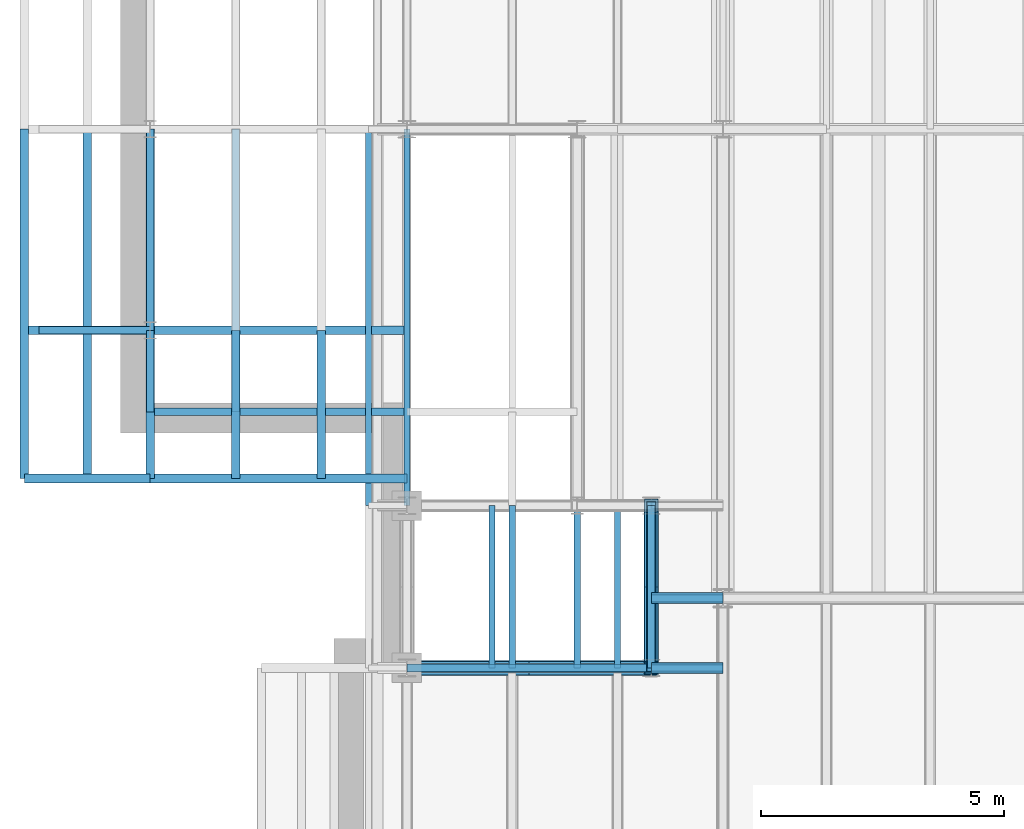
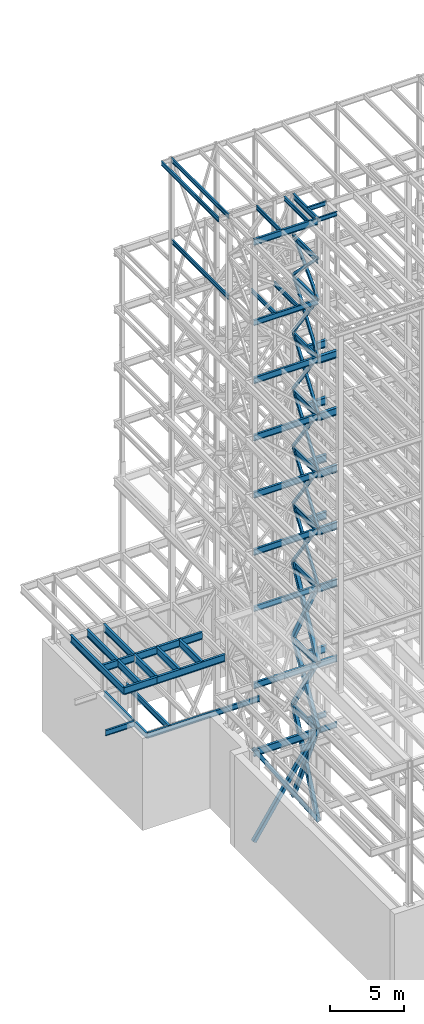
# One storey, part 125 of 150: 76 beams.
"""IFC2X3 building model written with IfcOpenShell, lengths in millimetres."""

from ifc_helpers import new_model, si_unit, frame, origin_with_axes, origin_2d_with_axis, place, context, subcontext, project, spatial, hollow_rectangle, i_section, extrude, material, type_object, element, save


model = new_model("IFC2X3")

# Units and contexts
model_context = context("Model", 3, precision=1e-05, world=origin_with_axes())
body_context = subcontext(model_context, "Body", "Model", "MODEL_VIEW")
ifc_project = project(units=[si_unit("LENGTHUNIT", "METRE", prefix="MILLI"), si_unit("AREAUNIT", "SQUARE_METRE"), si_unit("VOLUMEUNIT", "CUBIC_METRE"), si_unit("MASSUNIT", "GRAM", prefix="KILO"), si_unit("TIMEUNIT", "SECOND"), si_unit("PLANEANGLEUNIT", "RADIAN"), si_unit("SOLIDANGLEUNIT", "STERADIAN"), si_unit("THERMODYNAMICTEMPERATUREUNIT", "DEGREE_CELSIUS"), si_unit("LUMINOUSINTENSITYUNIT", "LUMEN")], contexts=[model_context])

# Site, building, storey
site_placement = place(None, origin_with_axes())
site = spatial("IfcSite", under=ifc_project, at=site_placement, CompositionType="ELEMENT")
building_placement = place(site_placement, origin_with_axes())
building = spatial("IfcBuilding", under=site, at=building_placement, Name="Undefined", CompositionType="ELEMENT")
storey_placement = place(building_placement, origin_with_axes())
storey = spatial("IfcBuildingStorey", under=building, at=storey_placement, Name="Undefined", CompositionType="ELEMENT", Elevation=0.0)

# Beams
ifc_material_1 = material()
beam_type_1 = type_object("IfcBeamType", Name="HSS8X8X3/8", PredefinedType="NOTDEFINED")
for number, where, z_axis, x_axis, name in (
    (1, (10312.39949708, 24384.0, 59207.4), (0.0, 0.708447258296166, 0.705763758075353), (0.0, -0.705763758075351, 0.708447258296168), "BEAM"),
    (2, (10312.39949708, 21043.9, 59207.4), (0.0, -0.708447258296166, 0.705763758075353), (0.0, 0.705763758075351, 0.708447258296168), "BEAM"),
):
    element("IfcBeam", number, at=place(storey_placement, frame(where, z_axis=z_axis, x_axis=x_axis)), inside=storey, type_object=beam_type_1, material=ifc_material_1, Name=name, ObjectType="HSS8X8X3/8", context=body_context, shape_type="SweptSolid", body=[
        extrude(hollow_rectangle(XDim=203.2, YDim=203.2, WallThickness=9.525, InnerFilletRadius=9.5249, OuterFilletRadius=19.0499, at=origin_2d_with_axis()), frame((4732.60349596287, 0.0, 0.0), z_axis=(-1.0, 0.0, 0.0), x_axis=(0.0, -1.0, 0.0)), (0.0, 0.0, 1.0), 4732.60349596287),
    ])
beam_1_placement = place(storey_placement, frame((10312.39949708, 24383.9994993247, 54482.9998858065), z_axis=(0.0, 0.816541853949868, 0.577286238141975), x_axis=(0.0, -0.577286238141973, 0.816541853949869)))
element("IfcBeam", 3, at=beam_1_placement, inside=storey, type_object=beam_type_1, material=ifc_material_1, Name="BEAM", ObjectType="HSS8X8X3/8", context=body_context, shape_type="SweptSolid", body=[
    extrude(hollow_rectangle(XDim=203.2, YDim=203.2, WallThickness=9.525, InnerFilletRadius=9.5249, OuterFilletRadius=19.0499, at=origin_2d_with_axis()), frame((5785.86390302957, 0.0, 0.0), z_axis=(-1.0, 0.0, 0.0), x_axis=(0.0, -1.0, 0.0)), (0.0, 0.0, 1.0), 5785.86390302957),
])
beam_2_placement = place(storey_placement, frame((10312.39949708, 21043.9, 54483.0), z_axis=(0.0, -0.816541853949868, 0.577286238141975), x_axis=(0.0, 0.577286238141973, 0.816541853949869)))
element("IfcBeam", 4, at=beam_2_placement, inside=storey, type_object=beam_type_1, material=ifc_material_1, Name="BEAM", ObjectType="HSS8X8X3/8", context=body_context, shape_type="SweptSolid", body=[
    extrude(hollow_rectangle(XDim=203.2, YDim=203.2, WallThickness=9.525, InnerFilletRadius=9.5249, OuterFilletRadius=19.0499, at=origin_2d_with_axis()), frame((5785.86409881878, 0.0, 3.21179976993034e-13), z_axis=(-1.0, 0.0, 0.0), x_axis=(0.0, -1.0, 0.0)), (0.0, 0.0, 1.0), 5785.86409881878),
])
for number, where, z_axis, x_axis, name in (
    (5, (10312.39949708, 24384.0, 40309.8), (0.0, 0.816541853949868, 0.577286238141975), (0.0, -0.577286238141973, 0.816541853949869), "BEAM"),
    (6, (10312.39949708, 21043.9, 40309.8), (0.0, -0.816541853949868, 0.577286238141975), (0.0, 0.577286238141973, 0.816541853949869), "BEAM"),
):
    element("IfcBeam", number, at=place(storey_placement, frame(where, z_axis=z_axis, x_axis=x_axis)), inside=storey, type_object=beam_type_1, material=ifc_material_1, Name=name, ObjectType="HSS8X8X3/8", context=body_context, shape_type="SweptSolid", body=[
        extrude(hollow_rectangle(XDim=203.2, YDim=203.2, WallThickness=9.525, InnerFilletRadius=9.5249, OuterFilletRadius=19.0499, at=origin_2d_with_axis()), frame((5785.86409881878, 0.0, 3.21179976993034e-13), z_axis=(-1.0, 0.0, 0.0), x_axis=(0.0, -1.0, 0.0)), (0.0, 0.0, 1.0), 5785.86409881877),
    ])
for number, where, z_axis, x_axis, name in (
    (7, (10312.39949708, 24384.0, 35585.4), (0.0, 0.816541853949868, 0.577286238141975), (0.0, -0.577286238141973, 0.816541853949869), "BEAM"),
    (8, (10312.39949708, 21043.9, 35585.4), (0.0, -0.816541853949868, 0.577286238141975), (0.0, 0.577286238141973, 0.816541853949869), "BEAM"),
):
    element("IfcBeam", number, at=place(storey_placement, frame(where, z_axis=z_axis, x_axis=x_axis)), inside=storey, type_object=beam_type_1, material=ifc_material_1, Name=name, ObjectType="HSS8X8X3/8", context=body_context, shape_type="SweptSolid", body=[
        extrude(hollow_rectangle(XDim=203.2, YDim=203.2, WallThickness=9.525, InnerFilletRadius=9.5249, OuterFilletRadius=19.0499, at=origin_2d_with_axis()), frame((5785.86409881878, 0.0, 3.21179976993034e-13), z_axis=(-1.0, 0.0, 0.0), x_axis=(0.0, -1.0, 0.0)), (0.0, 0.0, 1.0), 5785.86409881878),
    ])
ifc_material_2 = material(Name="STEEL/A992")
beam_type_2 = type_object("IfcBeamType", Name="W18X35", PredefinedType="NOTDEFINED")
for number, where, z_axis, x_axis, name in (
    (9, (10312.39949708, 21043.8997539549, 62334.7746954019), (0.0, 0.0, 1.0), (0.0, 1.0, 0.0), "BEAM"),
    (10, (10312.39949708, 21043.9, 65687.575), (0.0, 0.0, 1.0), (0.0, 1.0, 0.0), "BEAM"),
    (11, (10312.39949708, 21043.9, 58981.975), (0.0, 0.0, 1.0), (0.0, 1.0, 0.0), "BEAM"),
):
    element("IfcBeam", number, at=place(storey_placement, frame(where, z_axis=z_axis, x_axis=x_axis)), inside=storey, type_object=beam_type_2, material=ifc_material_2, Name=name, ObjectType="W18X35", context=body_context, shape_type="SweptSolid", body=[
        extrude(i_section(OverallWidth=152.4, OverallDepth=450.85, WebThickness=7.9375, FlangeThickness=10.795, FilletRadius=17.78, at=origin_2d_with_axis()), frame((3340.1, 0.0, 0.0), z_axis=(-1.0, 0.0, 0.0), x_axis=(0.0, -1.0, 0.0)), (0.0, 0.0, 1.0), 3340.1),
    ])
beam_3_placement = place(storey_placement, frame((5283.2, 21043.9, 58981.975), z_axis=(0.0, 0.0, 1.0), x_axis=(1.0, 0.0, 0.0)))
element("IfcBeam", 12, at=beam_3_placement, inside=storey, type_object=beam_type_2, material=ifc_material_2, Name="BEAM", ObjectType="W18X35", context=body_context, shape_type="SweptSolid", body=[
    extrude(i_section(OverallWidth=152.4, OverallDepth=450.85, WebThickness=7.9375, FlangeThickness=10.795, FilletRadius=17.78, at=origin_2d_with_axis()), frame((5029.19949708, 0.0, 0.0), z_axis=(-1.0, 0.0, 0.0), x_axis=(0.0, -1.0, 0.0)), (0.0, 0.0, 1.0), 5029.19949708),
])
for number, where, z_axis, x_axis, name in (
    (13, (10312.39949708, 21043.9, 54257.575), (0.0, 0.0, 1.0), (0.0, 1.0, 0.0), "BEAM"),
    (14, (10312.39949708, 21043.9, 49533.175), (0.0, 0.0, 1.0), (0.0, 1.0, 0.0), "BEAM"),
    (15, (10312.39949708, 21043.9, 44808.775), (0.0, 0.0, 1.0), (0.0, 1.0, 0.0), "BEAM"),
    (16, (10312.39949708, 21043.9, 40084.375), (0.0, 0.0, 1.0), (0.0, 1.0, 0.0), "BEAM"),
    (17, (10312.39949708, 21043.9, 35359.975), (0.0, 0.0, 1.0), (0.0, 1.0, 0.0), "BEAM"),
):
    element("IfcBeam", number, at=place(storey_placement, frame(where, z_axis=z_axis, x_axis=x_axis)), inside=storey, type_object=beam_type_2, material=ifc_material_2, Name=name, ObjectType="W18X35", context=body_context, shape_type="SweptSolid", body=[
        extrude(i_section(OverallWidth=152.4, OverallDepth=450.85, WebThickness=7.9375, FlangeThickness=10.795, FilletRadius=17.78, at=origin_2d_with_axis()), frame((3340.1, 0.0, 0.0), z_axis=(-1.0, 0.0, 0.0), x_axis=(0.0, -1.0, 0.0)), (0.0, 0.0, 1.0), 3340.1),
    ])
beam_4_placement = place(storey_placement, frame((5283.2, 21043.9, 35359.975), z_axis=(0.0, 0.0, 1.0), x_axis=(1.0, 0.0, 0.0)))
element("IfcBeam", 18, at=beam_4_placement, inside=storey, type_object=beam_type_2, material=ifc_material_2, Name="BEAM", ObjectType="W18X35", context=body_context, shape_type="SweptSolid", body=[
    extrude(i_section(OverallWidth=152.4, OverallDepth=450.85, WebThickness=7.9375, FlangeThickness=10.795, FilletRadius=17.78, at=origin_2d_with_axis()), frame((5029.19949708, 0.0, 0.0), z_axis=(-1.0, 0.0, 0.0), x_axis=(0.0, -1.0, 0.0)), (0.0, 0.0, 1.0), 5029.19949708),
])
beam_5_placement = place(storey_placement, frame((10312.39949708, 21043.9, 29060.775), z_axis=(0.0, 0.0, 1.0), x_axis=(0.0, 1.0, 0.0)))
element("IfcBeam", 19, at=beam_5_placement, inside=storey, type_object=beam_type_2, material=ifc_material_2, Name="BEAM", ObjectType="W18X35", context=body_context, shape_type="SweptSolid", body=[
    extrude(i_section(OverallWidth=152.4, OverallDepth=450.85, WebThickness=7.9375, FlangeThickness=10.795, FilletRadius=17.78, at=origin_2d_with_axis()), frame((3340.1, 0.0, 0.0), z_axis=(-1.0, 0.0, 0.0), x_axis=(0.0, -1.0, 0.0)), (0.0, 0.0, 1.0), 3340.1),
])
beam_6_placement = place(storey_placement, frame((1761.06666666667, 26314.4, 23548.975), z_axis=(0.0, 0.0, 1.0), x_axis=(0.0, 1.0, 0.0)))
element("IfcBeam", 20, at=beam_6_placement, inside=storey, type_object=beam_type_2, material=ifc_material_2, Name="BEAM", ObjectType="W18X35", context=body_context, shape_type="SweptSolid", body=[
    extrude(i_section(OverallWidth=152.4, OverallDepth=450.85, WebThickness=7.9375, FlangeThickness=10.795, FilletRadius=17.78, at=origin_2d_with_axis()), frame((5816.59941834001, 0.0, 0.0), z_axis=(-1.0, 0.0, 0.0), x_axis=(0.0, -1.0, 0.0)), (0.0, 0.0, 1.0), 5816.59941834001),
])
beam_7_placement = place(storey_placement, frame((0.0, 27990.8, 23548.975), z_axis=(0.0, 0.0, 1.0), x_axis=(0.0, 1.0, 0.0)))
element("IfcBeam", 21, at=beam_7_placement, inside=storey, type_object=beam_type_2, material=ifc_material_2, Name="BEAM", ObjectType="W18X35", context=body_context, shape_type="SweptSolid", body=[
    extrude(i_section(OverallWidth=152.4, OverallDepth=450.85, WebThickness=7.9375, FlangeThickness=10.795, FilletRadius=17.78, at=origin_2d_with_axis()), frame((4140.2, 0.0, 0.0), z_axis=(-1.0, 0.0, 0.0), x_axis=(0.0, -1.0, 0.0)), (0.0, 0.0, 1.0), 4140.2),
])
beam_8_placement = place(storey_placement, frame((-2286.0, 27990.8, 23548.975), z_axis=(0.0, 0.0, 1.0), x_axis=(1.0, 0.0, 0.0)))
element("IfcBeam", 22, at=beam_8_placement, inside=storey, type_object=beam_type_2, material=ifc_material_2, Name="BEAM", ObjectType="W18X35", context=body_context, shape_type="SweptSolid", body=[
    extrude(i_section(OverallWidth=152.4, OverallDepth=450.85, WebThickness=7.9375, FlangeThickness=10.795, FilletRadius=17.78, at=origin_2d_with_axis()), frame((2286.0, 0.0, 0.0), z_axis=(-1.0, 0.0, 0.0), x_axis=(0.0, -1.0, 0.0)), (0.0, 0.0, 1.0), 2286.0),
])
beam_9_placement = place(storey_placement, frame((0.0, 26314.4, 23548.975), z_axis=(0.0, 0.0, 1.0), x_axis=(0.0, 1.0, 0.0)))
element("IfcBeam", 23, at=beam_9_placement, inside=storey, type_object=beam_type_2, material=ifc_material_2, Name="BEAM", ObjectType="W18X35", context=body_context, shape_type="SweptSolid", body=[
    extrude(i_section(OverallWidth=152.4, OverallDepth=450.85, WebThickness=7.9375, FlangeThickness=10.795, FilletRadius=17.78, at=origin_2d_with_axis()), frame((1676.4, 0.0, 0.0), z_axis=(-1.0, 0.0, 0.0), x_axis=(0.0, -1.0, 0.0)), (0.0, 0.0, 1.0), 1676.4),
])
beam_10_placement = place(storey_placement, frame((0.0, 26314.4, 23548.975), z_axis=(0.0, 0.0, 1.0), x_axis=(1.0, 0.0, 0.0)))
element("IfcBeam", 24, at=beam_10_placement, inside=storey, type_object=beam_type_2, material=ifc_material_2, Name="BEAM", ObjectType="W18X35", context=body_context, shape_type="SweptSolid", body=[
    extrude(i_section(OverallWidth=152.4, OverallDepth=450.85, WebThickness=7.9375, FlangeThickness=10.795, FilletRadius=17.78, at=origin_2d_with_axis()), frame((8788.39949708, 0.0, 0.0), z_axis=(-1.0, 0.0, 0.0), x_axis=(0.0, -1.0, 0.0)), (0.0, 0.0, 1.0), 8788.39949708),
])
for number, where, z_axis, x_axis, name in (
    (25, (10312.39949708, 22479.0, 23548.975), (0.0, 0.0, 1.0), (1.0, 0.0, 0.0), "BEAM"),
    (26, (10312.39949708, 21043.9, 23548.975), (0.0, 0.0, 1.0), (1.0, 0.0, 0.0), "BEAM"),
):
    element("IfcBeam", number, at=place(storey_placement, frame(where, z_axis=z_axis, x_axis=x_axis)), inside=storey, type_object=beam_type_2, material=ifc_material_2, Name=name, ObjectType="W18X35", context=body_context, shape_type="SweptSolid", body=[
        extrude(i_section(OverallWidth=152.4, OverallDepth=450.85, WebThickness=7.9375, FlangeThickness=10.795, FilletRadius=17.78, at=origin_2d_with_axis()), frame((1473.20050292, 0.0, 0.0), z_axis=(-1.0, 0.0, 0.0), x_axis=(0.0, -1.0, 0.0)), (0.0, 0.0, 1.0), 1473.20050292),
    ])
beam_11_placement = place(storey_placement, frame((10312.39949708, 21043.9, 23548.975), z_axis=(0.0, 0.0, 1.0), x_axis=(0.0, 1.0, 0.0)))
element("IfcBeam", 27, at=beam_11_placement, inside=storey, type_object=beam_type_2, material=ifc_material_2, Name="BEAM", ObjectType="W18X35", context=body_context, shape_type="SweptSolid", body=[
    extrude(i_section(OverallWidth=152.4, OverallDepth=450.85, WebThickness=7.9375, FlangeThickness=10.795, FilletRadius=17.78, at=origin_2d_with_axis()), frame((3340.1, 0.0, 0.0), z_axis=(-1.0, 0.0, 0.0), x_axis=(0.0, -1.0, 0.0)), (0.0, 0.0, 1.0), 3340.09999999999),
])
beam_type_3 = type_object("IfcBeamType", Name="HSS8X8X1/4", PredefinedType="NOTDEFINED")
for number, where, z_axis, x_axis, name in (
    (28, (10312.39949708, 24384.0, 49758.6), (0.0, 0.816541853949868, 0.577286238141975), (0.0, -0.577286238141973, 0.816541853949869), "BEAM"),
    (29, (10312.39949708, 21043.9, 49758.6), (0.0, -0.816541853949868, 0.577286238141975), (0.0, 0.577286238141973, 0.816541853949869), "BEAM"),
):
    element("IfcBeam", number, at=place(storey_placement, frame(where, z_axis=z_axis, x_axis=x_axis)), inside=storey, type_object=beam_type_3, material=ifc_material_1, Name=name, ObjectType="HSS8X8X1/4", context=body_context, shape_type="SweptSolid", body=[
        extrude(hollow_rectangle(XDim=203.2, YDim=203.2, WallThickness=6.35, InnerFilletRadius=6.3499, OuterFilletRadius=12.6999, at=origin_2d_with_axis()), frame((5785.86409881878, 0.0, 3.21179976993034e-13), z_axis=(-1.0, 0.0, 0.0), x_axis=(0.0, -1.0, 0.0)), (0.0, 0.0, 1.0), 5785.86409881878),
    ])
beam_12_placement = place(storey_placement, frame((10312.39949708, 24384.0, 45034.2), z_axis=(0.0, 0.816541853949868, 0.577286238141975), x_axis=(0.0, -0.577286238141973, 0.816541853949869)))
element("IfcBeam", 30, at=beam_12_placement, inside=storey, type_object=beam_type_3, material=ifc_material_1, Name="BEAM", ObjectType="HSS8X8X1/4", context=body_context, shape_type="SweptSolid", body=[
    extrude(hollow_rectangle(XDim=203.2, YDim=203.2, WallThickness=6.35, InnerFilletRadius=6.3499, OuterFilletRadius=12.6999, at=origin_2d_with_axis()), frame((5785.86440767293, 0.0, 0.0), z_axis=(-1.0, 0.0, 0.0), x_axis=(0.0, -1.0, 0.0)), (0.0, 0.0, 1.0), 5785.86440767293),
])
beam_13_placement = place(storey_placement, frame((10312.39949708, 21043.9, 45034.2), z_axis=(0.0, -0.816541853949868, 0.577286238141975), x_axis=(0.0, 0.577286238141973, 0.816541853949869)))
element("IfcBeam", 31, at=beam_13_placement, inside=storey, type_object=beam_type_3, material=ifc_material_1, Name="BEAM", ObjectType="HSS8X8X1/4", context=body_context, shape_type="SweptSolid", body=[
    extrude(hollow_rectangle(XDim=203.2, YDim=203.2, WallThickness=6.35, InnerFilletRadius=6.3499, OuterFilletRadius=12.6999, at=origin_2d_with_axis()), frame((5785.86409881878, 0.0, 3.21179976993034e-13), z_axis=(-1.0, 0.0, 0.0), x_axis=(0.0, -1.0, 0.0)), (0.0, 0.0, 1.0), 5785.86409881877),
])
beam_type_4 = type_object("IfcBeamType", Name="HSS12X12X5/8", PredefinedType="NOTDEFINED")
beam_14_placement = place(storey_placement, frame((10312.39949708, 21043.9001130334, 16154.4), z_axis=(0.834609454374485, 0.0, 0.550842135887156), x_axis=(-0.550842135887154, 0.0, 0.834609454374486)))
element("IfcBeam", 32, at=beam_14_placement, inside=storey, type_object=beam_type_4, material=ifc_material_1, Name="BEAM", ObjectType="HSS12X12X5/8", context=body_context, shape_type="SweptSolid", body=[
    extrude(hollow_rectangle(XDim=304.8, YDim=304.8, WallThickness=15.875, InnerFilletRadius=15.875, OuterFilletRadius=31.75, at=origin_2d_with_axis()), frame((9130.01903510775, 0.0, 0.0), z_axis=(-1.0, 0.0, 0.0), x_axis=(0.0, -1.0, 0.0)), (0.0, 0.0, 1.0), 9130.01903510775),
])
beam_15_placement = place(storey_placement, frame((5283.2, 21043.9, 16154.4), z_axis=(-0.834609454374487, 0.0, 0.550842135887154), x_axis=(0.550842135887154, 0.0, 0.834609454374486)))
element("IfcBeam", 33, at=beam_15_placement, inside=storey, type_object=beam_type_4, material=ifc_material_1, Name="BEAM", ObjectType="HSS12X12X5/8", context=body_context, shape_type="SweptSolid", body=[
    extrude(hollow_rectangle(XDim=304.8, YDim=304.8, WallThickness=15.875, InnerFilletRadius=15.875, OuterFilletRadius=31.75, at=origin_2d_with_axis()), frame((9130.01903510775, 0.0, 0.0), z_axis=(-1.0, 0.0, 0.0), x_axis=(0.0, -1.0, 0.0)), (0.0, 0.0, 1.0), 9130.01903510774),
])
for number, where, z_axis, x_axis, name in (
    (34, (10312.39949708, 24384.0, 29286.2), (0.0, 0.883484433084898, 0.468460517543001), (0.0, -0.468460517543001, 0.883484433084898), "BEAM"),
    (35, (10312.39949708, 21043.9, 29286.2), (0.0, -0.883484433084898, 0.468460517543001), (0.0, 0.468460517543001, 0.883484433084898), "BEAM"),
):
    element("IfcBeam", number, at=place(storey_placement, frame(where, z_axis=z_axis, x_axis=x_axis)), inside=storey, type_object=beam_type_4, material=ifc_material_1, Name=name, ObjectType="HSS12X12X5/8", context=body_context, shape_type="SweptSolid", body=[
        extrude(hollow_rectangle(XDim=304.8, YDim=304.8, WallThickness=15.875, InnerFilletRadius=15.875, OuterFilletRadius=31.75, at=origin_2d_with_axis()), frame((7129.95011553376, 0.0, 0.0), z_axis=(-1.0, 0.0, 0.0), x_axis=(0.0, -1.0, 0.0)), (0.0, 0.0, 1.0), 7129.95011553376),
    ])
for number, where, z_axis, x_axis, name in (
    (36, (10312.39949708, 24384.0, 23774.4), (0.0, 0.855224291154239, 0.518258055238632), (0.0, -0.518258055238631, 0.85522429115424), "BEAM"),
    (37, (10312.39949708, 21043.9, 23774.4), (0.0, -0.855224291154239, 0.518258055238632), (0.0, 0.518258055238631, 0.85522429115424), "BEAM"),
):
    element("IfcBeam", number, at=place(storey_placement, frame(where, z_axis=z_axis, x_axis=x_axis)), inside=storey, type_object=beam_type_4, material=ifc_material_1, Name=name, ObjectType="HSS12X12X5/8", context=body_context, shape_type="SweptSolid", body=[
        extrude(hollow_rectangle(XDim=304.8, YDim=304.8, WallThickness=15.875, InnerFilletRadius=15.875, OuterFilletRadius=31.75, at=origin_2d_with_axis()), frame((6444.8589782865, 0.0, -7.15523082815583e-13), z_axis=(-1.0, 0.0, 0.0), x_axis=(0.0, -1.0, 0.0)), (0.0, 0.0, 1.0), 6444.85897828649),
    ])
for number, where, z_axis, x_axis, name in (
    (38, (10312.39949708, 24384.0, 16154.4), (0.0, 0.91587685388345, 0.401459323618912), (0.0, -0.401459323618911, 0.91587685388345), "BEAM"),
    (39, (10312.39949708, 21043.9, 16154.4), (0.0, -0.91587685388345, 0.401459323618912), (0.0, 0.401459323618911, 0.91587685388345), "BEAM"),
):
    element("IfcBeam", number, at=place(storey_placement, frame(where, z_axis=z_axis, x_axis=x_axis)), inside=storey, type_object=beam_type_4, material=ifc_material_1, Name=name, ObjectType="HSS12X12X5/8", context=body_context, shape_type="SweptSolid", body=[
        extrude(hollow_rectangle(XDim=304.8, YDim=304.8, WallThickness=15.875, InnerFilletRadius=15.875, OuterFilletRadius=31.75, at=origin_2d_with_axis()), frame((8319.89591341142, 0.0, 4.61847000277705e-13), z_axis=(-1.0, 0.0, 0.0), x_axis=(0.0, -1.0, 0.0)), (0.0, 0.0, 1.0), 8319.89591341142),
    ])
beam_type_5 = type_object("IfcBeamType", Name="W21X50", PredefinedType="NOTDEFINED")
beam_16_placement = place(storey_placement, frame((5283.2, 21043.9, 65647.8875), z_axis=(0.0, 0.0, 1.0), x_axis=(1.0, 0.0, 0.0)))
element("IfcBeam", 40, at=beam_16_placement, inside=storey, type_object=beam_type_5, material=ifc_material_2, Name="BEAM", ObjectType="W21X50", context=body_context, shape_type="SweptSolid", body=[
    extrude(i_section(OverallWidth=165.862, OverallDepth=530.225, WebThickness=9.5249, FlangeThickness=13.589, FilletRadius=18.1609, at=origin_2d_with_axis()), frame((5029.19949708, 0.0, 0.0), z_axis=(-1.0, 0.0, 0.0), x_axis=(0.0, -1.0, 0.0)), (0.0, 0.0, 1.0), 5029.19949708),
])
beam_type_6 = type_object("IfcBeamType", Name="W24X68", PredefinedType="NOTDEFINED")
for number, where, z_axis, x_axis, name in (
    (41, (10312.39949708, 21043.9, 54181.375), (0.0, 0.0, 1.0), (1.0, 0.0, 0.0), "BEAM"),
    (42, (10312.39949708, 22479.0, 54181.375), (0.0, 0.0, 1.0), (1.0, 0.0, 0.0), "BEAM"),
    (43, (10312.39949708, 21043.9, 49456.975), (0.0, 0.0, 1.0), (1.0, 0.0, 0.0), "BEAM"),
    (44, (10312.39949708, 22479.0, 49456.975), (0.0, 0.0, 1.0), (1.0, 0.0, 0.0), "BEAM"),
    (45, (10312.39949708, 21043.9, 44732.575), (0.0, 0.0, 1.0), (1.0, 0.0, 0.0), "BEAM"),
    (46, (10312.39949708, 22479.0, 44732.575), (0.0, 0.0, 1.0), (1.0, 0.0, 0.0), "BEAM"),
    (47, (10312.39949708, 21043.9, 40008.175), (0.0, 0.0, 1.0), (1.0, 0.0, 0.0), "BEAM"),
    (48, (10312.39949708, 22479.0, 40008.175), (0.0, 0.0, 1.0), (1.0, 0.0, 0.0), "BEAM"),
):
    element("IfcBeam", number, at=place(storey_placement, frame(where, z_axis=z_axis, x_axis=x_axis)), inside=storey, type_object=beam_type_6, material=ifc_material_2, Name=name, ObjectType="W24X68", context=body_context, shape_type="SweptSolid", body=[
        extrude(i_section(OverallWidth=227.838, OverallDepth=603.25, WebThickness=11.1125, FlangeThickness=14.859, FilletRadius=23.2409, at=origin_2d_with_axis()), frame((1473.20050292, 0.0, 0.0), z_axis=(-1.0, 0.0, 0.0), x_axis=(0.0, -1.0, 0.0)), (0.0, 0.0, 1.0), 1473.20050292),
    ])
beam_type_7 = type_object("IfcBeamType", Name="W14X22", PredefinedType="NOTDEFINED")
beam_17_placement = place(storey_placement, frame((4495.8, 24384.0, 65738.375), z_axis=(0.0, 0.0, 1.0), x_axis=(0.0, 1.0, 0.0)))
element("IfcBeam", 49, at=beam_17_placement, inside=storey, type_object=beam_type_7, material=ifc_material_2, Name="BEAM", ObjectType="W14X22", context=body_context, shape_type="SweptSolid", body=[
    extrude(i_section(OverallWidth=127.0, OverallDepth=349.25, WebThickness=6.3499, FlangeThickness=8.509, FilletRadius=18.4785, at=origin_2d_with_axis()), frame((7746.99845060008, 0.0, 0.0), z_axis=(-1.0, 0.0, 0.0), x_axis=(0.0, -1.0, 0.0)), (0.0, 0.0, 1.0), 7746.99845060008),
])
for number, where, z_axis, x_axis, name in (
    (50, (10312.39949708, 22479.0, 65738.375), (0.0, 0.0, 1.0), (1.0, 0.0, 0.0), "BEAM"),
    (51, (10312.39949708, 21043.9, 65738.375), (0.0, 0.0, 1.0), (1.0, 0.0, 0.0), "BEAM"),
):
    element("IfcBeam", number, at=place(storey_placement, frame(where, z_axis=z_axis, x_axis=x_axis)), inside=storey, type_object=beam_type_7, material=ifc_material_2, Name=name, ObjectType="W14X22", context=body_context, shape_type="SweptSolid", body=[
        extrude(i_section(OverallWidth=127.0, OverallDepth=349.25, WebThickness=6.3499, FlangeThickness=8.509, FilletRadius=18.4785, at=origin_2d_with_axis()), frame((1473.20050292, 0.0, 0.0), z_axis=(-1.0, 0.0, 0.0), x_axis=(0.0, -1.0, 0.0)), (0.0, 0.0, 1.0), 1473.20050292),
    ])
for number, where, z_axis, x_axis, name in (
    (52, (7450.66666666667, 21043.9, 65738.375), (0.0, 0.0, 1.0), (0.0, 1.0, 0.0), "BEAM"),
    (53, (9618.13333333333, 21043.9, 65738.375), (0.0, 0.0, 1.0), (0.0, 1.0, 0.0), "BEAM"),
):
    element("IfcBeam", number, at=place(storey_placement, frame(where, z_axis=z_axis, x_axis=x_axis)), inside=storey, type_object=beam_type_7, material=ifc_material_2, Name=name, ObjectType="W14X22", context=body_context, shape_type="SweptSolid", body=[
        extrude(i_section(OverallWidth=127.0, OverallDepth=349.25, WebThickness=6.3499, FlangeThickness=8.509, FilletRadius=18.4785, at=origin_2d_with_axis()), frame((3340.1, 0.0, 0.0), z_axis=(-1.0, 0.0, 0.0), x_axis=(0.0, -1.0, 0.0)), (0.0, 0.0, 1.0), 3340.1),
    ])
beam_18_placement = place(storey_placement, frame((5283.2, 24384.0, 65738.375), z_axis=(0.0, 0.0, 1.0), x_axis=(0.0, 1.0, 0.0)))
element("IfcBeam", 54, at=beam_18_placement, inside=storey, type_object=beam_type_7, material=ifc_material_2, Name="BEAM", ObjectType="W14X22", context=body_context, shape_type="SweptSolid", body=[
    extrude(i_section(OverallWidth=127.0, OverallDepth=349.25, WebThickness=6.3499, FlangeThickness=8.509, FilletRadius=18.4785, at=origin_2d_with_axis()), frame((7746.9992253, 0.0, 0.0), z_axis=(-1.0, 0.0, 0.0), x_axis=(0.0, -1.0, 0.0)), (0.0, 0.0, 1.0), 7746.9992253),
])
for number, where, z_axis, x_axis, name in (
    (55, (7035.79974854, 21043.9, 59032.775), (0.0, 0.0, 1.0), (0.0, 1.0, 0.0), "BEAM"),
    (56, (8788.39949708, 21043.9, 59032.775), (0.0, 0.0, 1.0), (0.0, 1.0, 0.0), "BEAM"),
):
    element("IfcBeam", number, at=place(storey_placement, frame(where, z_axis=z_axis, x_axis=x_axis)), inside=storey, type_object=beam_type_7, material=ifc_material_2, Name=name, ObjectType="W14X22", context=body_context, shape_type="SweptSolid", body=[
        extrude(i_section(OverallWidth=127.0, OverallDepth=349.25, WebThickness=6.3499, FlangeThickness=8.509, FilletRadius=18.4785, at=origin_2d_with_axis()), frame((3340.1, 0.0, 0.0), z_axis=(-1.0, 0.0, 0.0), x_axis=(0.0, -1.0, 0.0)), (0.0, 0.0, 1.0), 3340.1),
    ])
beam_19_placement = place(storey_placement, frame((5283.2, 24384.0, 59032.775), z_axis=(0.0, 0.0, 1.0), x_axis=(0.0, 1.0, 0.0)))
element("IfcBeam", 57, at=beam_19_placement, inside=storey, type_object=beam_type_7, material=ifc_material_2, Name="BEAM", ObjectType="W14X22", context=body_context, shape_type="SweptSolid", body=[
    extrude(i_section(OverallWidth=127.0, OverallDepth=349.25, WebThickness=6.3499, FlangeThickness=8.509, FilletRadius=18.4785, at=origin_2d_with_axis()), frame((7747.0, 0.0, 0.0), z_axis=(-1.0, 0.0, 0.0), x_axis=(0.0, -1.0, 0.0)), (0.0, 0.0, 1.0), 7747.0),
])
beam_type_8 = type_object("IfcBeamType", Name="W24X55", PredefinedType="NOTDEFINED")
for number, where, z_axis, x_axis, name in (
    (58, (3522.13333333333, 24942.8, 28986.1625), (0.0, 0.0, 1.0), (0.0, 1.0, 0.0), "BEAM"),
    (59, (1761.06666666667, 24942.8, 28986.1625), (0.0, 0.0, 1.0), (0.0, 1.0, 0.0), "BEAM"),
):
    element("IfcBeam", number, at=place(storey_placement, frame(where, z_axis=z_axis, x_axis=x_axis)), inside=storey, type_object=beam_type_8, material=ifc_material_2, Name=name, ObjectType="W24X55", context=body_context, shape_type="SweptSolid", body=[
        extrude(i_section(OverallWidth=178.054, OverallDepth=600.075, WebThickness=9.5249, FlangeThickness=12.827, FilletRadius=23.6854, at=origin_2d_with_axis()), frame((3048.0, 0.0, 0.0), z_axis=(-1.0, 0.0, 0.0), x_axis=(0.0, -1.0, 0.0)), (0.0, 0.0, 1.0), 3048.0),
    ])
beam_20_placement = place(storey_placement, frame((0.0, 24942.8, 28986.1625), z_axis=(0.0, 0.0, 1.0), x_axis=(1.0, 0.0, 0.0)))
element("IfcBeam", 60, at=beam_20_placement, inside=storey, type_object=beam_type_8, material=ifc_material_2, Name="BEAM", ObjectType="W24X55", context=body_context, shape_type="SweptSolid", body=[
    extrude(i_section(OverallWidth=178.054, OverallDepth=600.075, WebThickness=9.5249, FlangeThickness=12.827, FilletRadius=23.6854, at=origin_2d_with_axis()), frame((5283.2, 0.0, 0.0), z_axis=(-1.0, 0.0, 0.0), x_axis=(0.0, -1.0, 0.0)), (0.0, 0.0, 1.0), 5283.2),
])
beam_21_placement = place(storey_placement, frame((-1295.4, 27990.8, 28986.1625), z_axis=(0.0, 0.0, 1.0), x_axis=(0.0, 1.0, 0.0)))
element("IfcBeam", 61, at=beam_21_placement, inside=storey, type_object=beam_type_8, material=ifc_material_2, Name="BEAM", ObjectType="W24X55", context=body_context, shape_type="SweptSolid", body=[
    extrude(i_section(OverallWidth=178.054, OverallDepth=600.075, WebThickness=9.5249, FlangeThickness=12.827, FilletRadius=23.6854, at=origin_2d_with_axis()), frame((4140.2, 0.0, 0.0), z_axis=(-1.0, 0.0, 0.0), x_axis=(0.0, -1.0, 0.0)), (0.0, 0.0, 1.0), 4140.2),
])
beam_22_placement = place(storey_placement, frame((-1295.4, 24942.8, 28986.1625), z_axis=(0.0, 0.0, 1.0), x_axis=(0.0, 1.0, 0.0)))
element("IfcBeam", 62, at=beam_22_placement, inside=storey, type_object=beam_type_8, material=ifc_material_2, Name="BEAM", ObjectType="W24X55", context=body_context, shape_type="SweptSolid", body=[
    extrude(i_section(OverallWidth=178.054, OverallDepth=600.075, WebThickness=9.5249, FlangeThickness=12.827, FilletRadius=23.6854, at=origin_2d_with_axis()), frame((3048.0, 0.0, 0.0), z_axis=(-1.0, 0.0, 0.0), x_axis=(0.0, -1.0, 0.0)), (0.0, 0.0, 1.0), 3048.0),
])
beam_23_placement = place(storey_placement, frame((-2590.8, 24942.8, 28986.1625), z_axis=(0.0, 0.0, 1.0), x_axis=(1.0, 0.0, 0.0)))
element("IfcBeam", 63, at=beam_23_placement, inside=storey, type_object=beam_type_8, material=ifc_material_2, Name="BEAM", ObjectType="W24X55", context=body_context, shape_type="SweptSolid", body=[
    extrude(i_section(OverallWidth=178.054, OverallDepth=600.075, WebThickness=9.5249, FlangeThickness=12.827, FilletRadius=23.6854, at=origin_2d_with_axis()), frame((2590.8, 0.0, 0.0), z_axis=(-1.0, 0.0, 0.0), x_axis=(0.0, -1.0, 0.0)), (0.0, 0.0, 1.0), 2590.8),
])
beam_24_placement = place(storey_placement, frame((0.0, 27990.8, 28986.1625), z_axis=(0.0, 0.0, 1.0), x_axis=(0.0, 1.0, 0.0)))
element("IfcBeam", 64, at=beam_24_placement, inside=storey, type_object=beam_type_8, material=ifc_material_2, Name="BEAM", ObjectType="W24X55", context=body_context, shape_type="SweptSolid", body=[
    extrude(i_section(OverallWidth=178.054, OverallDepth=600.075, WebThickness=9.5249, FlangeThickness=12.827, FilletRadius=23.6854, at=origin_2d_with_axis()), frame((4140.2, 0.0, 0.0), z_axis=(-1.0, 0.0, 0.0), x_axis=(0.0, -1.0, 0.0)), (0.0, 0.0, 1.0), 4140.2),
])
beam_25_placement = place(storey_placement, frame((-2590.8, 24942.8, 28986.1625), z_axis=(0.0, 0.0, 1.0), x_axis=(0.0, 1.0, 0.0)))
element("IfcBeam", 65, at=beam_25_placement, inside=storey, type_object=beam_type_8, material=ifc_material_2, Name="BEAM", ObjectType="W24X55", context=body_context, shape_type="SweptSolid", body=[
    extrude(i_section(OverallWidth=178.054, OverallDepth=600.075, WebThickness=9.5249, FlangeThickness=12.827, FilletRadius=23.6854, at=origin_2d_with_axis()), frame((7188.2, 0.0, 0.0), z_axis=(-1.0, 0.0, 0.0), x_axis=(0.0, -1.0, 0.0)), (0.0, 0.0, 1.0), 7188.2),
])
beam_26_placement = place(storey_placement, frame((0.0, 24942.8, 28986.1625), z_axis=(0.0, 0.0, 1.0), x_axis=(0.0, 1.0, 0.0)))
element("IfcBeam", 66, at=beam_26_placement, inside=storey, type_object=beam_type_8, material=ifc_material_2, Name="BEAM", ObjectType="W24X55", context=body_context, shape_type="SweptSolid", body=[
    extrude(i_section(OverallWidth=178.054, OverallDepth=600.075, WebThickness=9.5249, FlangeThickness=12.827, FilletRadius=23.6854, at=origin_2d_with_axis()), frame((3048.0, 0.0, 0.0), z_axis=(-1.0, 0.0, 0.0), x_axis=(0.0, -1.0, 0.0)), (0.0, 0.0, 1.0), 3048.0),
])
beam_27_placement = place(storey_placement, frame((-2590.8, 27990.8, 28986.1625), z_axis=(0.0, 0.0, 1.0), x_axis=(1.0, 0.0, 0.0)))
element("IfcBeam", 67, at=beam_27_placement, inside=storey, type_object=beam_type_8, material=ifc_material_2, Name="BEAM", ObjectType="W24X55", context=body_context, shape_type="SweptSolid", body=[
    extrude(i_section(OverallWidth=178.054, OverallDepth=600.075, WebThickness=9.5249, FlangeThickness=12.827, FilletRadius=23.6854, at=origin_2d_with_axis()), frame((7874.0, 0.0, 0.0), z_axis=(-1.0, 0.0, 0.0), x_axis=(0.0, -1.0, 0.0)), (0.0, 0.0, 1.0), 7874.0),
])
beam_28_placement = place(storey_placement, frame((5283.2, 21043.9, 23474.3625), z_axis=(0.0, 0.0, 1.0), x_axis=(1.0, 0.0, 0.0)))
element("IfcBeam", 68, at=beam_28_placement, inside=storey, type_object=beam_type_8, material=ifc_material_2, Name="BEAM", ObjectType="W24X55", context=body_context, shape_type="SweptSolid", body=[
    extrude(i_section(OverallWidth=178.054, OverallDepth=600.075, WebThickness=9.5249, FlangeThickness=12.827, FilletRadius=23.6854, at=origin_2d_with_axis()), frame((5029.19949708, 0.0, 0.0), z_axis=(-1.0, 0.0, 0.0), x_axis=(0.0, -1.0, 0.0)), (0.0, 0.0, 1.0), 5029.19949708),
])
beam_type_9 = type_object("IfcBeamType", Name="W21X44", PredefinedType="NOTDEFINED")
for number, where, z_axis, x_axis, name in (
    (69, (5283.2, 21043.9, 54221.0625), (0.0, 0.0, 1.0), (1.0, 0.0, 0.0), "BEAM"),
    (70, (5283.2, 21043.9, 49496.6625), (0.0, 0.0, 1.0), (1.0, 0.0, 0.0), "BEAM"),
    (71, (5283.2, 21043.9, 44772.2625), (0.0, 0.0, 1.0), (1.0, 0.0, 0.0), "BEAM"),
    (72, (5283.2, 21043.9, 40047.8625), (0.0, 0.0, 1.0), (1.0, 0.0, 0.0), "BEAM"),
    (73, (5283.2, 21043.9, 29024.2625), (0.0, 0.0, 1.0), (1.0, 0.0, 0.0), "BEAM"),
):
    element("IfcBeam", number, at=place(storey_placement, frame(where, z_axis=z_axis, x_axis=x_axis)), inside=storey, type_object=beam_type_9, material=ifc_material_2, Name=name, ObjectType="W21X44", context=body_context, shape_type="SweptSolid", body=[
        extrude(i_section(OverallWidth=165.1, OverallDepth=523.875, WebThickness=9.5249, FlangeThickness=11.43, FilletRadius=17.145, at=origin_2d_with_axis()), frame((5029.19949708, 0.0, 0.0), z_axis=(-1.0, 0.0, 0.0), x_axis=(0.0, -1.0, 0.0)), (0.0, 0.0, 1.0), 5029.19949708),
    ])
beam_29_placement = place(storey_placement, frame((10312.39949708, 21043.9, 29024.2625), z_axis=(0.0, 0.0, 1.0), x_axis=(1.0, 0.0, 0.0)))
element("IfcBeam", 74, at=beam_29_placement, inside=storey, type_object=beam_type_9, material=ifc_material_2, Name="BEAM", ObjectType="W21X44", context=body_context, shape_type="SweptSolid", body=[
    extrude(i_section(OverallWidth=165.1, OverallDepth=523.875, WebThickness=9.5249, FlangeThickness=11.43, FilletRadius=17.145, at=origin_2d_with_axis()), frame((1473.20050292, 0.0, 0.0), z_axis=(-1.0, 0.0, 0.0), x_axis=(0.0, -1.0, 0.0)), (0.0, 0.0, 1.0), 1473.20050292),
])
beam_type_10 = type_object("IfcBeamType", Name="W24X62", PredefinedType="NOTDEFINED")
for number, where, z_axis, x_axis, name in (
    (75, (10312.39949708, 21043.9, 35283.775), (0.0, 0.0, 1.0), (1.0, 0.0, 0.0), "BEAM"),
    (76, (10312.39949708, 22479.0, 28984.575), (0.0, 0.0, 1.0), (1.0, 0.0, 0.0), "BEAM"),
):
    element("IfcBeam", number, at=place(storey_placement, frame(where, z_axis=z_axis, x_axis=x_axis)), inside=storey, type_object=beam_type_10, material=ifc_material_2, Name=name, ObjectType="W24X62", context=body_context, shape_type="SweptSolid", body=[
        extrude(i_section(OverallWidth=177.8, OverallDepth=603.25, WebThickness=11.1125, FlangeThickness=14.986, FilletRadius=23.114, at=origin_2d_with_axis()), frame((1473.20050292, 0.0, 0.0), z_axis=(-1.0, 0.0, 0.0), x_axis=(0.0, -1.0, 0.0)), (0.0, 0.0, 1.0), 1473.20050292),
    ])

save(model, "model.ifc")
